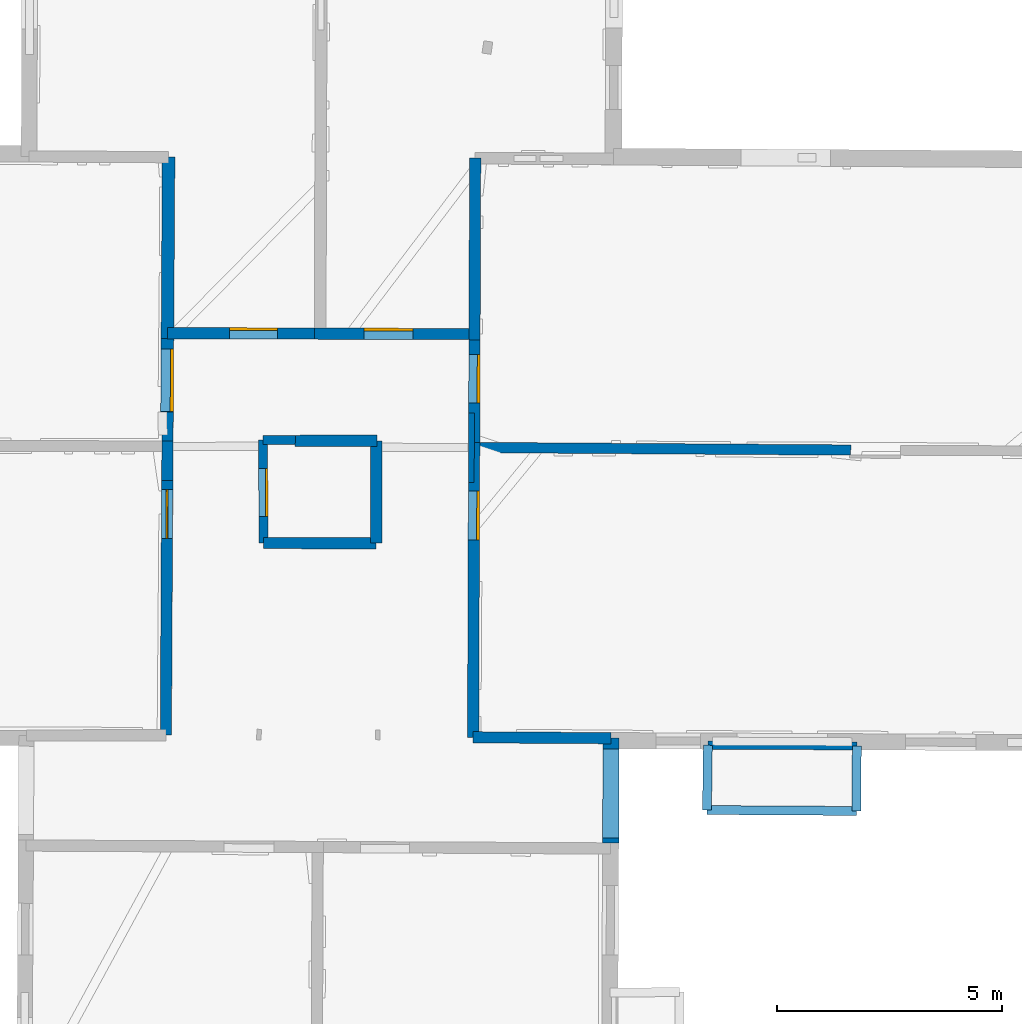
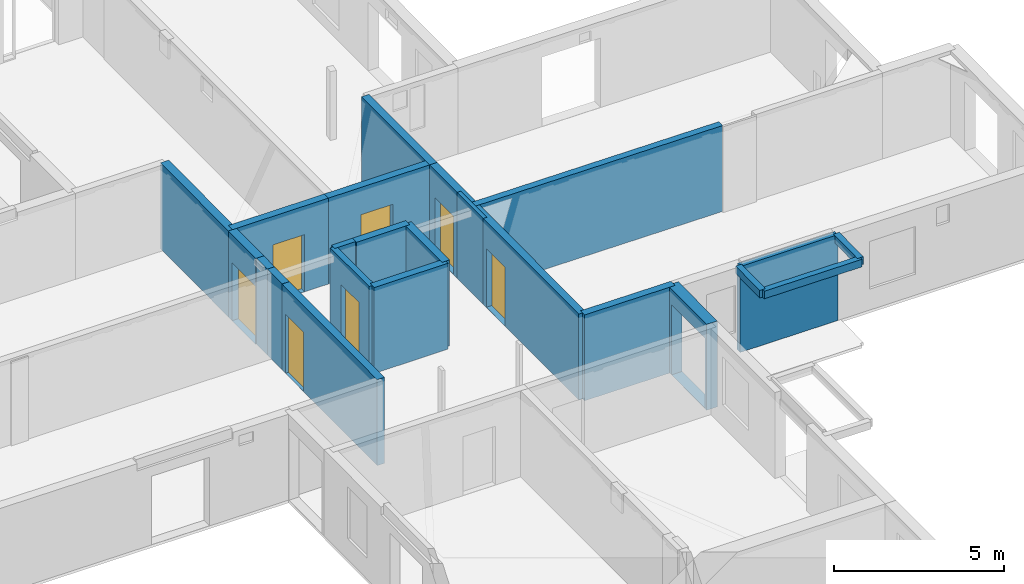
# One storey, part 8 of 15: 23 walls, 7 doors, 8 openings.
"""IFC2X3 building model written with IfcOpenShell, lengths in metres."""

from ifc_helpers import new_model, entity, si_unit, converted_unit, derived_unit, direction, frame, frame_2d, origin, origin_2d_with_axis, place, context, subcontext, project, spatial, polyline, rectangle, outline, extrude, source, transform, mapped, material, layer, layer_set, layer_usage, type_object, type_shapes, element, fill, save


model = new_model("IFC2X3")

# Units and contexts
model_context = context("Model", 3, precision=1e-05, world=origin(), true_north=direction((0.0, 1.0)))
body_context = subcontext(model_context, "Body", "Model", "MODEL_VIEW")
ifc_project = project(units=[si_unit("LENGTHUNIT", "METRE"), si_unit("AREAUNIT", "SQUARE_METRE"), si_unit("VOLUMEUNIT", "CUBIC_METRE"), converted_unit("PLANEANGLEUNIT", "DEGREE", entity("IfcRatioMeasure", 0.0174532925199433), si_unit("PLANEANGLEUNIT", "RADIAN"), dimensions=[0, 0, 0, 0, 0, 0, 0]), si_unit("MASSUNIT", "GRAM", prefix="KILO"), derived_unit("MASSDENSITYUNIT", [(si_unit("MASSUNIT", "GRAM", prefix="KILO"), 1), (si_unit("LENGTHUNIT", "METRE"), -3)]), derived_unit("MOMENTOFINERTIAUNIT", [(si_unit("LENGTHUNIT", "METRE"), 4)]), si_unit("TIMEUNIT", "SECOND"), si_unit("FREQUENCYUNIT", "HERTZ"), si_unit("THERMODYNAMICTEMPERATUREUNIT", "DEGREE_CELSIUS"), derived_unit("THERMALTRANSMITTANCEUNIT", [(si_unit("MASSUNIT", "GRAM", prefix="KILO"), 1), (si_unit("THERMODYNAMICTEMPERATUREUNIT", "KELVIN"), -1), (si_unit("TIMEUNIT", "SECOND"), -3)]), derived_unit("VOLUMETRICFLOWRATEUNIT", [(si_unit("LENGTHUNIT", "METRE"), 3), (si_unit("TIMEUNIT", "SECOND"), -1)]), si_unit("ELECTRICCURRENTUNIT", "AMPERE"), si_unit("ELECTRICVOLTAGEUNIT", "VOLT"), si_unit("POWERUNIT", "WATT"), si_unit("FORCEUNIT", "NEWTON", prefix="KILO"), si_unit("ILLUMINANCEUNIT", "LUX"), si_unit("LUMINOUSFLUXUNIT", "LUMEN"), si_unit("LUMINOUSINTENSITYUNIT", "CANDELA"), derived_unit("USERDEFINED", [(si_unit("MASSUNIT", "GRAM", prefix="KILO"), -1), (si_unit("LENGTHUNIT", "METRE"), -2), (si_unit("TIMEUNIT", "SECOND"), 3), (si_unit("LUMINOUSFLUXUNIT", "LUMEN"), 1)]), derived_unit("LINEARVELOCITYUNIT", [(si_unit("LENGTHUNIT", "METRE"), 1), (si_unit("TIMEUNIT", "SECOND"), -1)]), si_unit("PRESSUREUNIT", "PASCAL"), derived_unit("USERDEFINED", [(si_unit("LENGTHUNIT", "METRE"), -2), (si_unit("MASSUNIT", "GRAM", prefix="KILO"), 1), (si_unit("TIMEUNIT", "SECOND"), -2)]), derived_unit("LINEARFORCEUNIT", [(si_unit("MASSUNIT", "GRAM", prefix="KILO"), 1), (si_unit("LENGTHUNIT", "METRE"), 1), (si_unit("TIMEUNIT", "SECOND"), -2), (si_unit("LENGTHUNIT", "METRE"), -1)]), derived_unit("PLANARFORCEUNIT", [(si_unit("MASSUNIT", "GRAM", prefix="KILO"), 1), (si_unit("LENGTHUNIT", "METRE"), 1), (si_unit("TIMEUNIT", "SECOND"), -2), (si_unit("LENGTHUNIT", "METRE"), -2)])], contexts=[model_context])

# Site, building, storey
placement_1 = place(None, origin())
site = spatial("IfcSite", under=ifc_project, at=placement_1, CompositionType="ELEMENT")
building = spatial("IfcBuilding", under=site, at=placement_1, CompositionType="ELEMENT")
storey_placement = place(placement_1, frame((0.0, 0.0, 2.3807327747345)))
storey = spatial("IfcBuildingStorey", under=building, at=storey_placement, Name="Level 2", CompositionType="ELEMENT", Elevation=2.3807327747345)

# Wall, opening, door
ifc_material_1 = material(Name="Default wall")
ifc_layer_1 = layer(ifc_material_1, 0.25)
ifc_layer_set_1 = layer_set([ifc_layer_1], Name="wall_thickness_0.2500")
ifc_layer_usage_1 = layer_usage(ifc_layer_set_1, "AXIS2", "POSITIVE", -0.125)
wall_type_1 = type_object("IfcWallType", Name="wall_thickness_0.2500", PredefinedType="STANDARD", material=ifc_layer_set_1)
wall_1_placement = place(storey_placement, frame((2.97607672819855, 56.8915101102211, 0.0), z_axis=(0.0, 0.0, 1.0), x_axis=(-0.00533975548691596, -0.999985743404045, 0.0)))
wall_1 = element("IfcWallStandardCase", 1, at=wall_1_placement, inside=storey, type_object=wall_type_1, material=ifc_layer_usage_1, Name="Wall:687", ObjectType="Wall", context=body_context, shape_type="SweptSolid", body=[
    extrude(outline(polyline([(5.65466359354904, -0.125), (5.65466359354904, 0.125), (0.0, 0.125), (0.0, -0.125), (5.65466359354904, -0.125)])), origin(), (0.0, 0.0, 1.0), 3.08589615821838),
])
opening_1_placement = place(wall_1_placement, frame((0.205275598367296, -0.125, 0.00526785850524902)))
opening_1 = element("IfcOpeningElement", 2, at=opening_1_placement, cuts=wall_1, Name="Opening : 1085 x 2115 : 433", ObjectType="Opening", context=body_context, shape_type="SweptSolid", body=[
    extrude(rectangle(XDim=1.085, YDim=2.115, at=frame_2d((1.0575, 0.5425), x_axis=(0.0, 1.0))), frame((0.0, 0.0, 0.0), z_axis=(0.0, 1.0, 0.0), x_axis=(0.0, 0.0, 1.0)), (0.0, 0.0, 1.0), 0.25),
])
ifc_material_2 = material(Name="Door Panel")
door_style_1 = type_object("IfcDoorStyle", Name="Door : 1085 x 2115mm", ConstructionType="NOTDEFINED", OperationType="SINGLE_SWING_RIGHT", ParameterTakesPrecedence=False, Sizeable=False, material=ifc_material_2)
shared_shape_1 = source(origin(), body_context, "Body", "SweptSolid", [
    extrude(rectangle(XDim=0.0350000001490116, YDim=1.085, at=origin_2d_with_axis()), frame((0.5425, 0.122500000521541, 0.0), z_axis=(0.0, 0.0, 1.0), x_axis=(0.0, 1.0, 0.0)), (0.0, 0.0, 1.0), 2.115),
])
type_shapes(door_style_1, [shared_shape_1])
door_1_placement = place(opening_1_placement, origin())
door_1 = element("IfcDoor", 3, at=door_1_placement, inside=storey, type_object=door_style_1, Name="Door : 1085 x 2115mm : 83", ObjectType="Door : 1085 x 2115mm", OverallHeight=2.115, OverallWidth=1.085, context=body_context, shape_type="MappedRepresentation", body=[
    mapped(shared_shape_1, transform((0.0, 0.0, 0.0), scale=1.0)),
])
fill(opening_1, door_1)

# Walls
wall_2_placement = place(storey_placement, frame((5.10890055842952, 55.4994162564176, 0.0), z_axis=(0.0, 0.0, 1.0), x_axis=(0.999999242068239, -0.00123120386091064, 0.0)))
element("IfcWallStandardCase", 4, at=wall_2_placement, inside=storey, type_object=wall_type_1, material=ifc_layer_usage_1, Name="Wall:688", ObjectType="Wall", context=body_context, shape_type="SweptSolid", body=[
    extrude(outline(polyline([(2.50346468889827, -0.125), (2.50346468889827, 0.125), (0.0, 0.125), (0.0, -0.125), (2.50346468889827, -0.125)])), origin(), (0.0, 0.0, 1.0), 3.08589615821838),
])
wall_3_placement = place(storey_placement, frame((7.61833338557583, 57.7696607790973, 0.0), z_axis=(0.0, 0.0, 1.0), x_axis=(-0.00262588889945995, -0.999996552347801, 0.0)))
element("IfcWallStandardCase", 5, at=wall_3_placement, inside=storey, type_object=wall_type_1, material=ifc_layer_usage_1, Name="Wall:692", ObjectType="Wall", context=body_context, shape_type="SweptSolid", body=[
    extrude(outline(polyline([(2.27333471144671, -0.125), (2.27333471144671, 0.125), (0.0, 0.125), (0.0, -0.125), (2.27333471144671, -0.125)])), origin(), (0.0, 0.0, 1.0), 3.08589615821838),
])
wall_4_placement = place(storey_placement, frame((9.8106796074336, 64.0406802916802, 0.0), z_axis=(0.0, 0.0, 1.0), x_axis=(-0.00353729616344024, -0.999993743748356, 0.0)))
element("IfcWallStandardCase", 6, at=wall_4_placement, inside=storey, type_object=wall_type_1, material=ifc_layer_usage_1, Name="Wall:697", ObjectType="Wall", context=body_context, shape_type="SweptSolid", body=[
    extrude(outline(polyline([(4.02925341847254, -0.125), (4.02925341847254, 0.125), (0.0, 0.125), (0.0, -0.125), (4.02925341847254, -0.125)])), origin(), (0.0, 0.0, 1.0), 3.08589615821838),
])

# Wall, opening, door
wall_5_placement = place(storey_placement, frame((9.79642694477491, 60.0114520812309, 0.0), z_axis=(0.0, 0.0, 1.0), x_axis=(-0.00353729865707898, -0.999993743739535, 0.0)))
wall_5 = element("IfcWallStandardCase", 7, at=wall_5_placement, inside=storey, type_object=wall_type_1, material=ifc_layer_usage_1, Name="Wall:698", ObjectType="Wall", context=body_context, shape_type="SweptSolid", body=[
    extrude(outline(polyline([(2.27600758646425, -0.125), (2.27600758646425, 0.125), (0.0, 0.125), (0.0, -0.125), (2.27600758646425, -0.125)])), origin(), (0.0, 0.0, 1.0), 3.08589615821838),
])
opening_2_placement = place(wall_5_placement, frame((0.325422436317485, -0.125, 0.00526785850524902)))
opening_2 = element("IfcOpeningElement", 8, at=opening_2_placement, cuts=wall_5, Name="Opening : 1080 x 2095 : 441", ObjectType="Opening", context=body_context, shape_type="SweptSolid", body=[
    extrude(rectangle(XDim=1.08, YDim=2.095, at=frame_2d((1.0475, 0.54), x_axis=(0.0, 1.0))), frame((0.0, 0.0, 0.0), z_axis=(0.0, 1.0, 0.0), x_axis=(0.0, 0.0, 1.0)), (0.0, 0.0, 1.0), 0.25),
])
door_style_2 = type_object("IfcDoorStyle", Name="Door : 1080 x 2095mm", ConstructionType="NOTDEFINED", OperationType="SINGLE_SWING_RIGHT", ParameterTakesPrecedence=False, Sizeable=False, material=ifc_material_2)
shared_shape_2 = source(origin(), body_context, "Body", "SweptSolid", [
    extrude(rectangle(XDim=0.0625, YDim=1.08, at=origin_2d_with_axis()), frame((0.54, 0.21875, 0.0), z_axis=(0.0, 0.0, 1.0), x_axis=(0.0, 1.0, 0.0)), (0.0, 0.0, 1.0), 2.095),
])
type_shapes(door_style_2, [shared_shape_2])
door_2_placement = place(opening_2_placement, origin())
door_2 = element("IfcDoor", 9, at=door_2_placement, inside=storey, type_object=door_style_2, Name="Door : 1080 x 2095mm : 84", ObjectType="Door : 1080 x 2095mm", OverallHeight=2.095, OverallWidth=1.08, context=body_context, shape_type="MappedRepresentation", body=[
    mapped(shared_shape_2, transform((0.0, 0.0, 0.0), scale=1.0)),
])
fill(opening_2, door_2)

wall_6_placement = place(storey_placement, frame((9.78837602619581, 57.735458734063, 0.0), z_axis=(0.0, 0.0, 1.0), x_axis=(-0.00353738803795092, -0.999993743423362, 0.0)))
wall_6 = element("IfcWallStandardCase", 10, at=wall_6_placement, inside=storey, type_object=wall_type_1, material=ifc_layer_usage_1, Name="Wall:699", ObjectType="Wall", context=body_context, shape_type="SweptSolid", body=[
    extrude(outline(polyline([(6.54719825064528, -0.125), (6.54719825064528, 0.125), (0.0, 0.125), (0.0, -0.125), (6.54719825064528, -0.125)])), origin(), (0.0, 0.0, 1.0), 3.08589615821838),
])
opening_3_placement = place(wall_6_placement, frame((1.07839117514555, -0.125, 0.00526785850524902)))
opening_3 = element("IfcOpeningElement", 11, at=opening_3_placement, cuts=wall_6, Name="Opening : 1090 x 2115 : 442", ObjectType="Opening", context=body_context, shape_type="SweptSolid", body=[
    extrude(rectangle(XDim=1.09, YDim=2.115, at=frame_2d((1.0575, 0.545), x_axis=(0.0, 1.0))), frame((0.0, 0.0, 0.0), z_axis=(0.0, 1.0, 0.0), x_axis=(0.0, 0.0, 1.0)), (0.0, 0.0, 1.0), 0.25),
])
door_style_3 = type_object("IfcDoorStyle", Name="Door : 1090 x 2115mm", ConstructionType="NOTDEFINED", OperationType="SINGLE_SWING_RIGHT", ParameterTakesPrecedence=False, Sizeable=False, material=ifc_material_2)
shared_shape_3 = source(origin(), body_context, "Body", "SweptSolid", [
    extrude(rectangle(XDim=0.0625, YDim=1.09, at=origin_2d_with_axis()), frame((0.545, 0.21875, 0.0), z_axis=(0.0, 0.0, 1.0), x_axis=(0.0, 1.0, 0.0)), (0.0, 0.0, 1.0), 2.115),
])
type_shapes(door_style_3, [shared_shape_3])
door_3_placement = place(opening_3_placement, origin())
door_3 = element("IfcDoor", 12, at=door_3_placement, inside=storey, type_object=door_style_3, Name="Door : 1090 x 2115mm : 85", ObjectType="Door : 1090 x 2115mm", OverallHeight=2.115, OverallWidth=1.09, context=body_context, shape_type="MappedRepresentation", body=[
    mapped(shared_shape_3, transform((0.0, 0.0, 0.0), scale=1.0)),
])
fill(opening_3, door_3)

wall_7_placement = place(storey_placement, frame((2.98217076406268, 60.1589310518546, 0.0), z_axis=(0.0, 0.0, 1.0), x_axis=(0.999994558034246, -0.00329907591513292, 0.0)))
wall_7 = element("IfcWallStandardCase", 13, at=wall_7_placement, inside=storey, type_object=wall_type_1, material=ifc_layer_usage_1, Name="Wall:722", ObjectType="Wall", context=body_context, shape_type="SweptSolid", body=[
    extrude(outline(polyline([(3.25843271602864, -0.125), (3.25843271602864, 0.125), (0.0, 0.125), (0.0, -0.125), (3.25843271602864, -0.125)])), origin(), (0.0, 0.0, 1.0), 3.08589615821838),
])
opening_4_placement = place(wall_7_placement, frame((1.37672574328807, -0.125, 0.00526785850524902)))
opening_4 = element("IfcOpeningElement", 14, at=opening_4_placement, cuts=wall_7, Name="Opening : 1070 x 2055 : 458", ObjectType="Opening", context=body_context, shape_type="SweptSolid", body=[
    extrude(rectangle(XDim=1.07, YDim=2.055, at=frame_2d((1.0275, 0.535), x_axis=(0.0, 1.0))), frame((0.0, 0.0, 0.0), z_axis=(0.0, 1.0, 0.0), x_axis=(0.0, 0.0, 1.0)), (0.0, 0.0, 1.0), 0.25),
])
door_style_4 = type_object("IfcDoorStyle", Name="Door : 1070 x 2055mm", ConstructionType="NOTDEFINED", OperationType="SINGLE_SWING_RIGHT", ParameterTakesPrecedence=False, Sizeable=False, material=ifc_material_2)
shared_shape_4 = source(origin(), body_context, "Body", "SweptSolid", [
    extrude(rectangle(XDim=0.0625, YDim=1.07, at=origin_2d_with_axis()), frame((0.535, 0.21875, 0.0), z_axis=(0.0, 0.0, 1.0), x_axis=(0.0, 1.0, 0.0)), (0.0, 0.0, 1.0), 2.055),
])
type_shapes(door_style_4, [shared_shape_4])
door_4_placement = place(opening_4_placement, origin())
door_4 = element("IfcDoor", 15, at=door_4_placement, inside=storey, type_object=door_style_4, Name="Door : 1070 x 2055mm : 87", ObjectType="Door : 1070 x 2055mm", OverallHeight=2.055, OverallWidth=1.07, context=body_context, shape_type="MappedRepresentation", body=[
    mapped(shared_shape_4, transform((0.0, 0.0, 0.0), scale=1.0)),
])
fill(opening_4, door_4)

wall_8_placement = place(storey_placement, frame((6.24058574781207, 60.14818123496, 0.0), z_axis=(0.0, 0.0, 1.0), x_axis=(0.999994560183748, -0.00329842430739017, 0.0)))
wall_8 = element("IfcWallStandardCase", 16, at=wall_8_placement, inside=storey, type_object=wall_type_1, material=ifc_layer_usage_1, Name="Wall:723", ObjectType="Wall", context=body_context, shape_type="SweptSolid", body=[
    extrude(outline(polyline([(3.55630234276263, -0.125), (3.55630234276263, 0.125), (0.0, 0.125), (0.0, -0.125), (3.55630234276263, -0.125)])), origin(), (0.0, 0.0, 1.0), 3.08589615821838),
])
opening_5_placement = place(wall_8_placement, frame((1.09829345635003, -0.125, 0.00526785850524902)))
opening_5 = element("IfcOpeningElement", 17, at=opening_5_placement, cuts=wall_8, Name="Opening : 1095 x 2100 : 459", ObjectType="Opening", context=body_context, shape_type="SweptSolid", body=[
    extrude(rectangle(XDim=1.095, YDim=2.1, at=frame_2d((1.05, 0.5475), x_axis=(0.0, 1.0))), frame((0.0, 0.0, 0.0), z_axis=(0.0, 1.0, 0.0), x_axis=(0.0, 0.0, 1.0)), (0.0, 0.0, 1.0), 0.25),
])
door_style_5 = type_object("IfcDoorStyle", Name="Door : 1095 x 2100mm", ConstructionType="NOTDEFINED", OperationType="SINGLE_SWING_RIGHT", ParameterTakesPrecedence=False, Sizeable=False, material=ifc_material_2)
shared_shape_5 = source(origin(), body_context, "Body", "SweptSolid", [
    extrude(rectangle(XDim=0.0625, YDim=1.095, at=origin_2d_with_axis()), frame((0.5475, 0.21875, 0.0), z_axis=(0.0, 0.0, 1.0), x_axis=(0.0, 1.0, 0.0)), (0.0, 0.0, 1.0), 2.1),
])
type_shapes(door_style_5, [shared_shape_5])
door_5_placement = place(opening_5_placement, origin())
door_5 = element("IfcDoor", 18, at=door_5_placement, inside=storey, type_object=door_style_5, Name="Door : 1095 x 2100mm : 88", ObjectType="Door : 1095 x 2100mm", OverallHeight=2.1, OverallWidth=1.095, context=body_context, shape_type="MappedRepresentation", body=[
    mapped(shared_shape_5, transform((0.0, 0.0, 0.0), scale=1.0)),
])
fill(opening_5, door_5)

# Walls
wall_9_placement = place(storey_placement, frame((2.98640655497456, 58.4123801081705, 0.0), z_axis=(0.0, 0.0, 1.0), x_axis=(-0.00616350662776014, -0.999981005412628, 0.0)))
element("IfcWallStandardCase", 19, at=wall_9_placement, inside=storey, type_object=wall_type_1, material=ifc_layer_usage_1, Name="Wall:735", ObjectType="Wall", context=body_context, shape_type="SweptSolid", body=[
    extrude(outline(polyline([(0.646458507239942, -0.125), (0.646458507239942, 0.125), (0.0, 0.125), (0.0, -0.125), (0.646458507239942, -0.125)])), origin(), (0.0, 0.0, 1.0), 3.08589615821838),
])
wall_10_placement = place(storey_placement, frame((2.98242210368062, 57.7659338801432, 0.0), z_axis=(0.0, 0.0, 1.0), x_axis=(-0.00616374051963578, -0.999981003970979, 0.0)))
element("IfcWallStandardCase", 20, at=wall_10_placement, inside=storey, type_object=wall_type_1, material=ifc_layer_usage_1, Name="Wall:736", ObjectType="Wall", context=body_context, shape_type="SweptSolid", body=[
    extrude(outline(polyline([(0.874341407598738, -0.125), (0.874341407598738, 0.125), (0.0, 0.125), (0.0, -0.125), (0.874341407598738, -0.125)])), origin(), (0.0, 0.0, 1.0), 3.08589615821838),
])
wall_11_placement = place(storey_placement, frame((5.81730876426377, 57.7671812777673, 0.0), z_axis=(0.0, 0.0, 1.0), x_axis=(0.999999054452379, 0.00137517066171401, 0.0)))
element("IfcWallStandardCase", 21, at=wall_11_placement, inside=storey, type_object=wall_type_1, material=ifc_layer_usage_1, Name="Wall:753", ObjectType="Wall", context=body_context, shape_type="SweptSolid", body=[
    extrude(outline(polyline([(1.81973152563549, -0.125), (1.81973152563549, 0.125), (0.0, 0.125), (0.0, -0.125), (1.81973152563549, -0.125)])), origin(), (0.0, 0.0, 1.0), 3.08589615821838),
])
wall_12_placement = place(storey_placement, frame((9.76521589236351, 51.1883061913228, 0.0), z_axis=(0.0, 0.0, 1.0), x_axis=(0.999979811501162, -0.0063542576356988, 0.0)))
element("IfcWallStandardCase", 22, at=wall_12_placement, inside=storey, type_object=wall_type_1, material=ifc_layer_usage_1, Name="Wall:782", ObjectType="Wall", context=body_context, shape_type="SweptSolid", body=[
    extrude(outline(polyline([(3.06292041730826, -0.125), (3.06292041730826, 0.125), (0.0, 0.125), (0.0, -0.125), (3.06292041730826, -0.125)])), origin(), (0.0, 0.0, 1.0), 3.08589615821838),
])

# Wall, opening, door
ifc_layer_2 = layer(ifc_material_1, 0.2)
ifc_layer_set_2 = layer_set([ifc_layer_2], Name="wall_thickness_0.2000")
ifc_layer_usage_2 = layer_usage(ifc_layer_set_2, "AXIS2", "POSITIVE", -0.1)
wall_type_2 = type_object("IfcWallType", Name="wall_thickness_0.2000", PredefinedType="STANDARD", material=ifc_layer_set_2)
wall_13_placement = place(storey_placement, frame((5.10625269898022, 57.7923174733564, 0.0), z_axis=(0.0, 0.0, 1.0), x_axis=(0.00115502277090548, -0.999999332960977, 0.0)))
wall_13 = element("IfcWallStandardCase", 23, at=wall_13_placement, inside=storey, type_object=wall_type_2, material=ifc_layer_usage_2, Name="Wall:702", ObjectType="Wall", context=body_context, shape_type="SweptSolid", body=[
    extrude(outline(polyline([(2.29290161490407, -0.1), (2.29290161490407, 0.1), (0.0, 0.1), (0.0, -0.1), (2.29290161490407, -0.1)])), origin(), (0.0, 0.0, 1.0), 3.08589615821838),
])
opening_6_placement = place(wall_13_placement, frame((0.632698456589053, -0.1, 0.00526785850524902)))
opening_6 = element("IfcOpeningElement", 24, at=opening_6_placement, cuts=wall_13, Name="Opening : 1075 x 2145 : 443", ObjectType="Opening", context=body_context, shape_type="SweptSolid", body=[
    extrude(rectangle(XDim=1.075, YDim=2.145, at=frame_2d((1.0725, 0.5375), x_axis=(0.0, 1.0))), frame((0.0, 0.0, 0.0), z_axis=(0.0, 1.0, 0.0), x_axis=(0.0, 0.0, 1.0)), (0.0, 0.0, 1.0), 0.2),
])
door_style_6 = type_object("IfcDoorStyle", Name="Door : 1075 x 2145mm", ConstructionType="NOTDEFINED", OperationType="SINGLE_SWING_RIGHT", ParameterTakesPrecedence=False, Sizeable=False, material=ifc_material_2)
shared_shape_6 = source(origin(), body_context, "Body", "SweptSolid", [
    extrude(rectangle(XDim=0.05, YDim=1.075, at=origin_2d_with_axis()), frame((0.5375, 0.175, 0.0), z_axis=(0.0, 0.0, 1.0), x_axis=(0.0, 1.0, 0.0)), (0.0, 0.0, 1.0), 2.145),
])
type_shapes(door_style_6, [shared_shape_6])
door_6_placement = place(opening_6_placement, origin())
door_6 = element("IfcDoor", 25, at=door_6_placement, inside=storey, type_object=door_style_6, Name="Door : 1075 x 2145mm : 86", ObjectType="Door : 1075 x 2145mm", OverallHeight=2.145, OverallWidth=1.075, context=body_context, shape_type="MappedRepresentation", body=[
    mapped(shared_shape_6, transform((0.0, 0.0, 0.0), scale=1.0)),
])
fill(opening_6, door_6)

# Walls
wall_14_placement = place(storey_placement, frame((5.10625252408977, 57.7923226995648, 0.0), z_axis=(0.0, 0.0, 1.0), x_axis=(0.999998406195154, -0.00178538711537137, 0.0)))
element("IfcWallStandardCase", 26, at=wall_14_placement, inside=storey, type_object=wall_type_2, material=ifc_layer_usage_2, Name="Wall:790", ObjectType="Wall", context=body_context, shape_type="SweptSolid", body=[
    extrude(outline(polyline([(0.711495102947966, -0.1), (0.711495102947966, 0.1), (0.0, 0.1), (0.0, -0.1), (0.711495102947966, -0.1)])), origin(), (0.0, 0.0, 1.0), 3.08589615821838),
])
placement_2 = place(placement_1, frame((0.0, 0.0, 5.19400024414062)))
wall_15_placement = place(placement_2, frame((14.9559574310544, 49.5741846737979, 0.0), z_axis=(0.0, 0.0, 1.0), x_axis=(0.999982187668118, -0.00596861344747289, 0.0)))
element("IfcWallStandardCase", 27, at=wall_15_placement, inside=storey, type_object=wall_type_2, material=ifc_layer_usage_2, Name="Wall:791", ObjectType="Wall", context=body_context, shape_type="SweptSolid", body=[
    extrude(outline(polyline([(3.31386937625189, -0.1), (3.31386937625189, 0.1), (0.0, 0.1), (0.0, -0.1), (3.31386937625189, -0.1)])), origin(), (0.0, 0.0, 1.0), 0.272628688812256),
])
placement_3 = place(placement_1, frame((0.0, 0.0, 5.19400024414062)))
wall_16_placement = place(placement_3, frame((14.9559570110298, 49.5741897943909, 0.0), z_axis=(0.0, 0.0, 1.0), x_axis=(0.0124896139036978, 0.999922001730403, 0.0)))
element("IfcWallStandardCase", 28, at=wall_16_placement, inside=storey, type_object=wall_type_2, material=ifc_layer_usage_2, Name="Wall:806", ObjectType="Wall", context=body_context, shape_type="SweptSolid", body=[
    extrude(outline(polyline([(1.43895500943826, -0.1), (1.43895500943826, 0.1), (0.0, 0.1), (0.0, -0.1), (1.43895500943826, -0.1)])), origin(), (0.0, 0.0, 1.0), 0.272628688812256),
])
placement_4 = place(placement_1, frame((0.0, 0.0, 5.19400024414062)))
wall_17_placement = place(placement_4, frame((18.28088044573, 50.9981813065198, 0.0), z_axis=(0.0, 0.0, 1.0), x_axis=(-0.00769642916040394, -0.999970382050478, 0.0)))
element("IfcWallStandardCase", 29, at=wall_17_placement, inside=storey, type_object=wall_type_2, material=ifc_layer_usage_2, Name="Wall:829", ObjectType="Wall", context=body_context, shape_type="SweptSolid", body=[
    extrude(outline(polyline([(1.44381412511856, -0.1), (1.44381412511856, 0.1), (0.0, 0.1), (0.0, -0.1), (1.44381412511856, -0.1)])), origin(), (0.0, 0.0, 1.0), 0.272628688812256),
])
ifc_layer_3 = layer(ifc_material_1, 0.129999995231628)
ifc_layer_set_3 = layer_set([ifc_layer_3], Name="wall_thickness_0.1300")
ifc_layer_usage_3 = layer_usage(ifc_layer_set_3, "AXIS2", "POSITIVE", -0.0649999976158142)
wall_type_3 = type_object("IfcWallType", Name="wall_thickness_0.1300", PredefinedType="STANDARD", material=ifc_layer_set_3)
wall_18_placement = place(storey_placement, frame((9.72939695945767, 58.3857670459923, 0.0), z_axis=(0.0, 0.0, 1.0), x_axis=(-0.00413823316779172, -0.999991437476466, 0.0)))
element("IfcWallStandardCase", 30, at=wall_18_placement, inside=storey, type_object=wall_type_3, material=ifc_layer_usage_3, Name="Wall:745", ObjectType="Wall", context=body_context, shape_type="SweptSolid", body=[
    extrude(outline(polyline([(1.54312310682675, -0.0649999976158142), (1.54312310682675, 0.0649999976158142), (0.0, 0.0649999976158142), (0.0, -0.0649999976158142), (1.54312310682675, -0.0649999976158142)])), origin(), (0.0, 0.0, 1.0), 3.08589615821838),
])
ifc_layer_4 = layer(ifc_material_1, 0.180000007152557)
ifc_layer_set_4 = layer_set([ifc_layer_4], Name="wall_thickness_0.1800")
ifc_layer_usage_4 = layer_usage(ifc_layer_set_4, "AXIS2", "POSITIVE", -0.0900000035762787)
wall_type_4 = type_object("IfcWallType", Name="wall_thickness_0.1800", PredefinedType="STANDARD", material=ifc_layer_set_4)
wall_19_placement = place(storey_placement, frame((14.9739278023335, 51.0130299513948, 0.0), z_axis=(0.0, 0.0, 1.0), x_axis=(0.999989922017469, -0.00448952820430557, 0.0)))
element("IfcWallStandardCase", 31, at=wall_19_placement, inside=storey, type_object=wall_type_4, material=ifc_layer_usage_4, Name="Wall:710", ObjectType="Wall", context=body_context, shape_type="SweptSolid", body=[
    extrude(outline(polyline([(3.3069848505627, -0.0900000035762787), (3.3069848505627, 0.0900000035762787), (0.0, 0.0900000035762787), (0.0, -0.0900000035762787), (3.3069848505627, -0.0900000035762787)])), origin(), (0.0, 0.0, 1.0), 3.08589615821838),
])

# Wall, opening
ifc_layer_5 = layer(ifc_material_1, 0.360000014305115)
ifc_layer_set_5 = layer_set([ifc_layer_5], Name="wall_thickness_0.3600")
ifc_layer_usage_5 = layer_usage(ifc_layer_set_5, "AXIS2", "POSITIVE", -0.180000007152557)
wall_type_5 = type_object("IfcWallType", Name="wall_thickness_0.3600", PredefinedType="STANDARD", material=ifc_layer_set_5)
wall_20_placement = place(storey_placement, frame((12.8280755691048, 51.1688508055234, 0.0), z_axis=(0.0, 0.0, 1.0), x_axis=(-0.00443417828247511, -0.999990168983155, 0.0)))
wall_20 = element("IfcWallStandardCase", 32, at=wall_20_placement, inside=storey, type_object=wall_type_5, material=ifc_layer_usage_5, Name="Wall:795", ObjectType="Wall", context=body_context, shape_type="SweptSolid", body=[
    extrude(outline(polyline([(2.32193368512347, -0.180000007152557), (2.32193368512347, 0.180000007152557), (0.0, 0.180000007152557), (0.0, -0.180000007152557), (2.32193368512347, -0.180000007152557)])), origin(), (0.0, 0.0, 1.0), 3.08589615821838),
])
opening_7_placement = place(wall_20_placement, frame((0.235491187061469, -0.180000007152557, 0.00526785850524902)))
element("IfcOpeningElement", 33, at=opening_7_placement, cuts=wall_20, Name="Opening : 1975 x 2520 : 502", ObjectType="Opening", context=body_context, shape_type="SweptSolid", body=[
    extrude(rectangle(XDim=1.975, YDim=2.52, at=frame_2d((1.26, 0.9875), x_axis=(0.0, 1.0))), frame((0.0, 0.0, 0.0), z_axis=(0.0, 1.0, 0.0), x_axis=(0.0, 0.0, 1.0)), (0.0, 0.0, 1.0), 0.360000014305115),
])

# Walls
ifc_layer_6 = layer(ifc_material_1, 0.230000004172325)
ifc_layer_set_6 = layer_set([ifc_layer_6], Name="wall_thickness_0.2300")
ifc_layer_usage_6 = layer_usage(ifc_layer_set_6, "AXIS2", "POSITIVE", -0.115000002086163)
wall_type_6 = type_object("IfcWallType", Name="wall_thickness_0.2300", PredefinedType="STANDARD", material=ifc_layer_set_6)
wall_21_placement = place(storey_placement, frame((9.7879682613247, 57.6204610269171, 0.0), z_axis=(0.0, 0.0, 1.0), x_axis=(0.999976911637033, -0.00679530667894882, 0.0)))
element("IfcWallStandardCase", 34, at=wall_21_placement, inside=storey, type_object=wall_type_6, material=ifc_layer_usage_6, Name="Wall:824", ObjectType="Wall", context=body_context, shape_type="SweptSolid", body=[
    extrude(outline(polyline([(8.35827288911656, -0.115000002086163), (8.35827288911656, 0.115000002086163), (0.0, 0.115000002086163), (0.0, -0.115000002086163), (8.35827288911656, -0.115000002086163)])), origin(), (0.0, 0.0, 1.0), 3.08589615821838),
])
ifc_layer_7 = layer(ifc_material_1, 0.280000001192093)
ifc_layer_set_7 = layer_set([ifc_layer_7], Name="wall_thickness_0.2800")
ifc_layer_usage_7 = layer_usage(ifc_layer_set_7, "AXIS2", "POSITIVE", -0.140000000596046)
wall_type_7 = type_object("IfcWallType", Name="wall_thickness_0.2800", PredefinedType="STANDARD", material=ifc_layer_set_7)
wall_22_placement = place(storey_placement, frame((3.00624050908685, 64.0636070723505, 0.0), z_axis=(0.0, 0.0, 1.0), x_axis=(-0.00616394469695261, -0.999981002712438, 0.0)))
element("IfcWallStandardCase", 35, at=wall_22_placement, inside=storey, type_object=wall_type_7, material=ifc_layer_usage_7, Name="Wall:733", ObjectType="Wall", context=body_context, shape_type="SweptSolid", body=[
    extrude(outline(polyline([(4.02975108436945, -0.140000000596046), (4.02975108436945, 0.140000000596046), (0.0, 0.140000000596046), (0.0, -0.140000000596046), (4.02975108436945, -0.140000000596046)])), origin(), (0.0, 0.0, 1.0), 3.08589615821838),
])

# Wall, opening, door
wall_23_placement = place(storey_placement, frame((2.98140134626031, 60.0339325423212, 0.0), z_axis=(0.0, 0.0, 1.0), x_axis=(-0.00616377660783794, -0.999981003748536, 0.0)))
wall_23 = element("IfcWallStandardCase", 36, at=wall_23_placement, inside=storey, type_object=wall_type_7, material=ifc_layer_usage_7, Name="Wall:734", ObjectType="Wall", context=body_context, shape_type="SweptSolid", body=[
    extrude(outline(polyline([(1.62149076318378, -0.140000000596046), (1.62149076318378, 0.140000000596046), (0.0, 0.140000000596046), (0.0, -0.140000000596046), (1.62149076318378, -0.140000000596046)])), origin(), (0.0, 0.0, 1.0), 3.08589615821838),
])
opening_8_placement = place(wall_23_placement, frame((0.226707954830237, -0.140000000596046, 0.00526785850524902)))
opening_8 = element("IfcOpeningElement", 37, at=opening_8_placement, cuts=wall_23, Name="Opening : 1390 x 2080 : 473", ObjectType="Opening", context=body_context, shape_type="SweptSolid", body=[
    extrude(rectangle(XDim=1.39, YDim=2.08, at=frame_2d((1.04, 0.695), x_axis=(0.0, 1.0))), frame((0.0, 0.0, 0.0), z_axis=(0.0, 1.0, 0.0), x_axis=(0.0, 0.0, 1.0)), (0.0, 0.0, 1.0), 0.280000001192093),
])
door_style_7 = type_object("IfcDoorStyle", Name="Door : 1390 x 2080mm", ConstructionType="NOTDEFINED", OperationType="SINGLE_SWING_RIGHT", ParameterTakesPrecedence=False, Sizeable=False, material=ifc_material_2)
shared_shape_7 = source(origin(), body_context, "Body", "SweptSolid", [
    extrude(rectangle(XDim=0.0700000002980232, YDim=1.39, at=origin_2d_with_axis()), frame((0.695, 0.245000001043081, 0.0), z_axis=(0.0, 0.0, 1.0), x_axis=(0.0, 1.0, 0.0)), (0.0, 0.0, 1.0), 2.08),
])
type_shapes(door_style_7, [shared_shape_7])
door_7_placement = place(opening_8_placement, origin())
door_7 = element("IfcDoor", 38, at=door_7_placement, inside=storey, type_object=door_style_7, Name="Door : 1390 x 2080mm : 89", ObjectType="Door : 1390 x 2080mm", OverallHeight=2.08, OverallWidth=1.39, context=body_context, shape_type="MappedRepresentation", body=[
    mapped(shared_shape_7, transform((0.0, 0.0, 0.0), scale=1.0)),
])
fill(opening_8, door_7)

save(model, "model.ifc")
